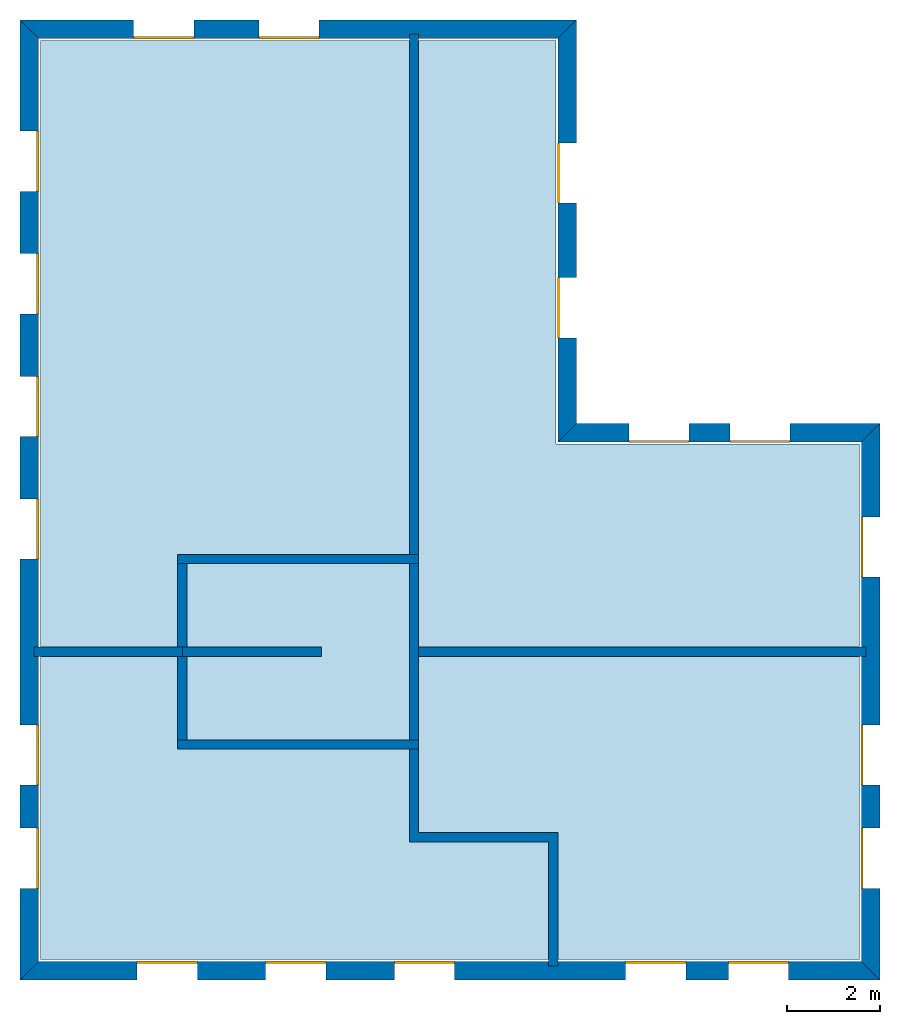
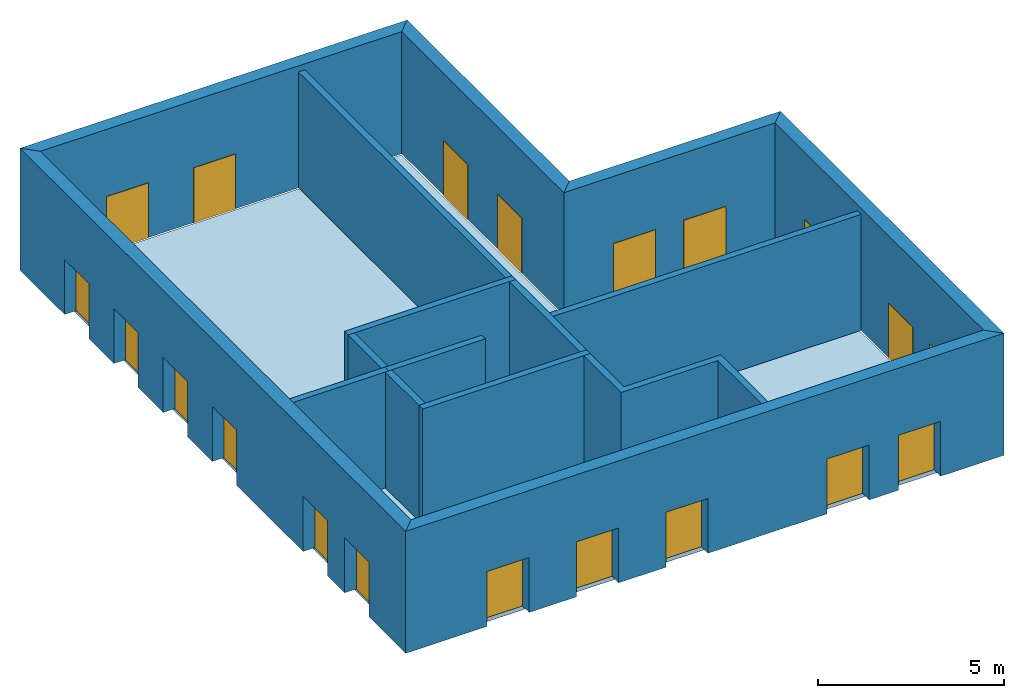
# One storey: 20 windows, 15 walls, 1 slab, 20 openings.
"""IFC4 building model written with IfcOpenShell, lengths in metres."""

from ifc_helpers import new_model, si_unit, origin_with_axes, place, context, subcontext, project, spatial, line, indexed_curve, outline, extrude, element, fill, save


model = new_model("IFC4")

# Units and contexts
model_context = context("Model", 3, precision=1e-05, world=origin_with_axes())
body_context = subcontext(model_context, "Body", "Model", "MODEL_VIEW")
ifc_project = project(units=[si_unit("AREAUNIT", "SQUARE_METRE"), si_unit("VOLUMEUNIT", "CUBIC_METRE"), si_unit("LENGTHUNIT", "METRE")], contexts=[model_context])

# Site, building, storey
site = spatial("IfcSite", under=ifc_project)
building = spatial("IfcBuilding", under=site, Name="Building 2")
storey_placement = place(None, origin_with_axes())
storey = spatial("IfcBuildingStorey", under=building, at=storey_placement, Name="01 Storey")

# Slab
slab_placement = place(storey_placement, origin_with_axes())
element("IfcSlab", 1, at=slab_placement, inside=storey, Name="Slab", context=body_context, shape_type="SweptSolid", body=[
    extrude(outline(indexed_curve([(22.099464, -3.599175), (15.553354, -3.599175), (15.553354, 5.1082), (4.433354, 5.1082), (4.433354, -14.719175), (22.099464, -14.719175)], segments=[line(1, 2), line(2, 3), line(3, 4), line(4, 5), line(5, 6)])), origin_with_axes(), (0.0, 0.0, -1.0), 0.2),
])

# Walls
wall_1_placement = place(storey_placement, origin_with_axes())
element("IfcWall", 2, at=wall_1_placement, inside=storey, Name="Wall", context=body_context, shape_type="SweptSolid", body=[
    extrude(outline(indexed_curve([(7.593354, -7.978543), (4.293354, -7.978543), (4.293354, -8.178543), (7.593354, -8.178543)], segments=[line(1, 2), line(2, 3), line(3, 4)])), origin_with_axes(), (0.0, 0.0, 1.0), 3.8),
])
wall_2_placement = place(storey_placement, origin_with_axes())
element("IfcWall", 3, at=wall_2_placement, inside=storey, Name="Wall", context=body_context, shape_type="SweptSolid", body=[
    extrude(outline(indexed_curve([(12.593354, 5.2482), (12.393354, 5.2482), (12.393354, -6.178543), (12.593354, -6.178543)], segments=[line(1, 2), line(2, 3), line(3, 4)])), origin_with_axes(), (0.0, 0.0, 1.0), 3.8),
])
wall_3_placement = place(storey_placement, origin_with_axes())
element("IfcWall", 4, at=wall_3_placement, inside=storey, Name="Wall", context=body_context, shape_type="SweptSolid", body=[
    extrude(outline(indexed_curve([(22.239464, -7.978543), (12.393354, -7.978543), (12.393354, -8.178543), (22.239464, -8.178543)], segments=[line(1, 2), line(2, 3), line(3, 4)])), origin_with_axes(), (0.0, 0.0, 1.0), 3.8),
])
wall_4_placement = place(storey_placement, origin_with_axes())
element("IfcWall", 5, at=wall_4_placement, inside=storey, Name="Wall", context=body_context, shape_type="SweptSolid", body=[
    extrude(outline(indexed_curve([(15.593354, -11.978543), (12.593354, -11.978543), (12.593354, -9.978543), (12.393354, -9.978543), (12.393354, -12.178543), (15.393354, -12.178543), (15.393354, -14.859175), (15.593354, -14.859175)], segments=[line(1, 2), line(2, 3), line(3, 4), line(4, 5), line(5, 6), line(6, 7), line(7, 8)])), origin_with_axes(), (0.0, 0.0, 1.0), 3.8),
])

# Wall, openings, windows
wall_5_placement = place(storey_placement, origin_with_axes())
wall_5 = element("IfcWall", 6, at=wall_5_placement, inside=storey, Name="Facade", context=body_context, shape_type="SweptSolid", body=[
    extrude(outline(indexed_curve([(22.139464, -3.559175), (15.593354, -3.559175), (15.993354, -3.159175), (22.539464, -3.159175)], segments=[line(1, 2), line(2, 3), line(3, 4)])), origin_with_axes(), (0.0, 0.0, 1.0), 4.0),
])
opening_1_placement = place(wall_5_placement, origin_with_axes())
opening_1 = element("IfcOpeningElement", 7, at=opening_1_placement, cuts=wall_5, Name="Opening", context=body_context, shape_type="SweptSolid", body=[
    extrude(outline(indexed_curve([(20.6074273333333, -3.119175), (20.6074273333333, -3.619175), (19.3074273333333, -3.619175), (19.3074273333333, -3.119175)], segments=[line(1, 2), line(2, 3), line(3, 4)])), origin_with_axes(), (0.0, 0.0, 1.0), 1.8),
])
opening_2_placement = place(wall_5_placement, origin_with_axes())
opening_2 = element("IfcOpeningElement", 8, at=opening_2_placement, cuts=wall_5, Name="Opening", context=body_context, shape_type="SweptSolid", body=[
    extrude(outline(indexed_curve([(18.4253906666667, -3.119175), (18.4253906666667, -3.619175), (17.1253906666667, -3.619175), (17.1253906666667, -3.119175)], segments=[line(1, 2), line(2, 3), line(3, 4)])), origin_with_axes(), (0.0, 0.0, 1.0), 1.8),
])
window_1_placement = place(storey_placement, origin_with_axes())
window_1 = element("IfcWindow", 9, at=window_1_placement, inside=storey, Name="Window", PredefinedType="WINDOW", context=body_context, shape_type="SweptSolid", body=[
    extrude(outline(indexed_curve([(20.6074273333333, -3.519175), (20.6074273333333, -3.569175), (19.3074273333333, -3.569175), (19.3074273333333, -3.519175)], segments=[line(1, 2), line(2, 3), line(3, 4)])), origin_with_axes(), (0.0, 0.0, 1.0), 1.8),
])
fill(opening_1, window_1)
window_2_placement = place(storey_placement, origin_with_axes())
window_2 = element("IfcWindow", 10, at=window_2_placement, inside=storey, Name="Window", PredefinedType="WINDOW", context=body_context, shape_type="SweptSolid", body=[
    extrude(outline(indexed_curve([(18.4253906666667, -3.519175), (18.4253906666667, -3.569175), (17.1253906666667, -3.569175), (17.1253906666667, -3.519175)], segments=[line(1, 2), line(2, 3), line(3, 4)])), origin_with_axes(), (0.0, 0.0, 1.0), 1.8),
])
fill(opening_2, window_2)

wall_6_placement = place(storey_placement, origin_with_axes())
wall_6 = element("IfcWall", 11, at=wall_6_placement, inside=storey, Name="Facade", context=body_context, shape_type="SweptSolid", body=[
    extrude(outline(indexed_curve([(15.593354, -3.559175), (15.593354, 5.1482), (15.993354, 5.5482), (15.993354, -3.159175)], segments=[line(1, 2), line(2, 3), line(3, 4)])), origin_with_axes(), (0.0, 0.0, 1.0), 4.0),
])
opening_3_placement = place(wall_6_placement, origin_with_axes())
opening_3 = element("IfcOpeningElement", 12, at=opening_3_placement, cuts=wall_6, Name="Opening", context=body_context, shape_type="SweptSolid", body=[
    extrude(outline(indexed_curve([(16.033354, -1.30671666666667), (15.533354, -1.30671666666667), (15.533354, -0.00671666666666659), (16.033354, -0.00671666666666659)], segments=[line(1, 2), line(2, 3), line(3, 4)])), origin_with_axes(), (0.0, 0.0, 1.0), 1.8),
])
opening_4_placement = place(wall_6_placement, origin_with_axes())
opening_4 = element("IfcOpeningElement", 13, at=opening_4_placement, cuts=wall_6, Name="Opening", context=body_context, shape_type="SweptSolid", body=[
    extrude(outline(indexed_curve([(16.033354, 1.59574166666667), (15.533354, 1.59574166666667), (15.533354, 2.89574166666667), (16.033354, 2.89574166666667)], segments=[line(1, 2), line(2, 3), line(3, 4)])), origin_with_axes(), (0.0, 0.0, 1.0), 1.8),
])
window_3_placement = place(storey_placement, origin_with_axes())
window_3 = element("IfcWindow", 14, at=window_3_placement, inside=storey, Name="Window", PredefinedType="WINDOW", context=body_context, shape_type="SweptSolid", body=[
    extrude(outline(indexed_curve([(15.633354, -1.30671666666667), (15.583354, -1.30671666666667), (15.583354, -0.00671666666666659), (15.633354, -0.00671666666666659)], segments=[line(1, 2), line(2, 3), line(3, 4)])), origin_with_axes(), (0.0, 0.0, 1.0), 1.8),
])
fill(opening_3, window_3)
window_4_placement = place(storey_placement, origin_with_axes())
window_4 = element("IfcWindow", 15, at=window_4_placement, inside=storey, Name="Window", PredefinedType="WINDOW", context=body_context, shape_type="SweptSolid", body=[
    extrude(outline(indexed_curve([(15.633354, 1.59574166666667), (15.583354, 1.59574166666667), (15.583354, 2.89574166666667), (15.633354, 2.89574166666667)], segments=[line(1, 2), line(2, 3), line(3, 4)])), origin_with_axes(), (0.0, 0.0, 1.0), 1.8),
])
fill(opening_4, window_4)

wall_7_placement = place(storey_placement, origin_with_axes())
wall_7 = element("IfcWall", 16, at=wall_7_placement, inside=storey, Name="Facade", context=body_context, shape_type="SweptSolid", body=[
    extrude(outline(indexed_curve([(15.593354, 5.1482), (4.393354, 5.1482), (3.993354, 5.5482), (15.993354, 5.5482)], segments=[line(1, 2), line(2, 3), line(3, 4)])), origin_with_axes(), (0.0, 0.0, 1.0), 4.0),
])
opening_5_placement = place(wall_7_placement, origin_with_axes())
opening_5 = element("IfcOpeningElement", 17, at=opening_5_placement, cuts=wall_7, Name="Opening", context=body_context, shape_type="SweptSolid", body=[
    extrude(outline(indexed_curve([(10.443354, 5.5882), (10.443354, 5.0882), (9.143354, 5.0882), (9.143354, 5.5882)], segments=[line(1, 2), line(2, 3), line(3, 4)])), origin_with_axes(), (0.0, 0.0, 1.0), 1.8),
])
opening_6_placement = place(wall_7_placement, origin_with_axes())
opening_6 = element("IfcOpeningElement", 18, at=opening_6_placement, cuts=wall_7, Name="Opening", context=body_context, shape_type="SweptSolid", body=[
    extrude(outline(indexed_curve([(7.743354, 5.5882), (7.743354, 5.0882), (6.443354, 5.0882), (6.443354, 5.5882)], segments=[line(1, 2), line(2, 3), line(3, 4)])), origin_with_axes(), (0.0, 0.0, 1.0), 1.8),
])
window_5_placement = place(storey_placement, origin_with_axes())
window_5 = element("IfcWindow", 19, at=window_5_placement, inside=storey, Name="Window", PredefinedType="WINDOW", context=body_context, shape_type="SweptSolid", body=[
    extrude(outline(indexed_curve([(10.443354, 5.1882), (10.443354, 5.1382), (9.143354, 5.1382), (9.143354, 5.1882)], segments=[line(1, 2), line(2, 3), line(3, 4)])), origin_with_axes(), (0.0, 0.0, 1.0), 1.8),
])
fill(opening_5, window_5)
window_6_placement = place(storey_placement, origin_with_axes())
window_6 = element("IfcWindow", 20, at=window_6_placement, inside=storey, Name="Window", PredefinedType="WINDOW", context=body_context, shape_type="SweptSolid", body=[
    extrude(outline(indexed_curve([(7.743354, 5.1882), (7.743354, 5.1382), (6.443354, 5.1382), (6.443354, 5.1882)], segments=[line(1, 2), line(2, 3), line(3, 4)])), origin_with_axes(), (0.0, 0.0, 1.0), 1.8),
])
fill(opening_6, window_6)

wall_8_placement = place(storey_placement, origin_with_axes())
wall_8 = element("IfcWall", 21, at=wall_8_placement, inside=storey, Name="Facade", context=body_context, shape_type="SweptSolid", body=[
    extrude(outline(indexed_curve([(4.393354, 5.1482), (4.393354, -14.759175), (3.993354, -15.159175), (3.993354, 5.5482)], segments=[line(1, 2), line(2, 3), line(3, 4)])), origin_with_axes(), (0.0, 0.0, 1.0), 4.0),
])
opening_7_placement = place(wall_8_placement, origin_with_axes())
opening_7 = element("IfcOpeningElement", 22, at=opening_7_placement, cuts=wall_8, Name="Opening", context=body_context, shape_type="SweptSolid", body=[
    extrude(outline(indexed_curve([(3.953354, 3.1528514), (4.453354, 3.1528514), (4.453354, 1.8528514), (3.953354, 1.8528514)], segments=[line(1, 2), line(2, 3), line(3, 4)])), origin_with_axes(), (0.0, 0.0, 1.0), 1.8),
])
opening_8_placement = place(wall_8_placement, origin_with_axes())
opening_8 = element("IfcOpeningElement", 23, at=opening_8_placement, cuts=wall_8, Name="Opening", context=body_context, shape_type="SweptSolid", body=[
    extrude(outline(indexed_curve([(3.953354, 0.507502800000001), (4.453354, 0.507502800000001), (4.453354, -0.792497199999999), (3.953354, -0.792497199999999)], segments=[line(1, 2), line(2, 3), line(3, 4)])), origin_with_axes(), (0.0, 0.0, 1.0), 1.8),
])
opening_9_placement = place(wall_8_placement, origin_with_axes())
opening_9 = element("IfcOpeningElement", 24, at=opening_9_placement, cuts=wall_8, Name="Opening", context=body_context, shape_type="SweptSolid", body=[
    extrude(outline(indexed_curve([(3.953354, -2.1378458), (4.453354, -2.1378458), (4.453354, -3.4378458), (3.953354, -3.4378458)], segments=[line(1, 2), line(2, 3), line(3, 4)])), origin_with_axes(), (0.0, 0.0, 1.0), 1.8),
])
opening_10_placement = place(wall_8_placement, origin_with_axes())
opening_10 = element("IfcOpeningElement", 25, at=opening_10_placement, cuts=wall_8, Name="Opening", context=body_context, shape_type="SweptSolid", body=[
    extrude(outline(indexed_curve([(3.953354, -4.7831944), (4.453354, -4.7831944), (4.453354, -6.0831944), (3.953354, -6.0831944)], segments=[line(1, 2), line(2, 3), line(3, 4)])), origin_with_axes(), (0.0, 0.0, 1.0), 1.8),
])
opening_11_placement = place(wall_8_placement, origin_with_axes())
opening_11 = element("IfcOpeningElement", 26, at=opening_11_placement, cuts=wall_8, Name="Opening", context=body_context, shape_type="SweptSolid", body=[
    extrude(outline(indexed_curve([(3.953354, -9.65542033333333), (4.453354, -9.65542033333333), (4.453354, -10.9554203333333), (3.953354, -10.9554203333333)], segments=[line(1, 2), line(2, 3), line(3, 4)])), origin_with_axes(), (0.0, 0.0, 1.0), 1.8),
])
opening_12_placement = place(wall_8_placement, origin_with_axes())
opening_12 = element("IfcOpeningElement", 27, at=opening_12_placement, cuts=wall_8, Name="Opening", context=body_context, shape_type="SweptSolid", body=[
    extrude(outline(indexed_curve([(3.953354, -11.8822976666667), (4.453354, -11.8822976666667), (4.453354, -13.1822976666667), (3.953354, -13.1822976666667)], segments=[line(1, 2), line(2, 3), line(3, 4)])), origin_with_axes(), (0.0, 0.0, 1.0), 1.8),
])
window_7_placement = place(storey_placement, origin_with_axes())
window_7 = element("IfcWindow", 28, at=window_7_placement, inside=storey, Name="Window", PredefinedType="WINDOW", context=body_context, shape_type="SweptSolid", body=[
    extrude(outline(indexed_curve([(4.353354, 3.1528514), (4.403354, 3.1528514), (4.403354, 1.8528514), (4.353354, 1.8528514)], segments=[line(1, 2), line(2, 3), line(3, 4)])), origin_with_axes(), (0.0, 0.0, 1.0), 1.8),
])
fill(opening_7, window_7)
window_8_placement = place(storey_placement, origin_with_axes())
window_8 = element("IfcWindow", 29, at=window_8_placement, inside=storey, Name="Window", PredefinedType="WINDOW", context=body_context, shape_type="SweptSolid", body=[
    extrude(outline(indexed_curve([(4.353354, 0.507502800000001), (4.403354, 0.507502800000001), (4.403354, -0.792497199999999), (4.353354, -0.792497199999999)], segments=[line(1, 2), line(2, 3), line(3, 4)])), origin_with_axes(), (0.0, 0.0, 1.0), 1.8),
])
fill(opening_8, window_8)
window_9_placement = place(storey_placement, origin_with_axes())
window_9 = element("IfcWindow", 30, at=window_9_placement, inside=storey, Name="Window", PredefinedType="WINDOW", context=body_context, shape_type="SweptSolid", body=[
    extrude(outline(indexed_curve([(4.353354, -2.1378458), (4.403354, -2.1378458), (4.403354, -3.4378458), (4.353354, -3.4378458)], segments=[line(1, 2), line(2, 3), line(3, 4)])), origin_with_axes(), (0.0, 0.0, 1.0), 1.8),
])
fill(opening_9, window_9)
window_10_placement = place(storey_placement, origin_with_axes())
window_10 = element("IfcWindow", 31, at=window_10_placement, inside=storey, Name="Window", PredefinedType="WINDOW", context=body_context, shape_type="SweptSolid", body=[
    extrude(outline(indexed_curve([(4.353354, -4.7831944), (4.403354, -4.7831944), (4.403354, -6.0831944), (4.353354, -6.0831944)], segments=[line(1, 2), line(2, 3), line(3, 4)])), origin_with_axes(), (0.0, 0.0, 1.0), 1.8),
])
fill(opening_10, window_10)
window_11_placement = place(storey_placement, origin_with_axes())
window_11 = element("IfcWindow", 32, at=window_11_placement, inside=storey, Name="Window", PredefinedType="WINDOW", context=body_context, shape_type="SweptSolid", body=[
    extrude(outline(indexed_curve([(4.353354, -9.65542033333333), (4.403354, -9.65542033333333), (4.403354, -10.9554203333333), (4.353354, -10.9554203333333)], segments=[line(1, 2), line(2, 3), line(3, 4)])), origin_with_axes(), (0.0, 0.0, 1.0), 1.8),
])
fill(opening_11, window_11)
window_12_placement = place(storey_placement, origin_with_axes())
window_12 = element("IfcWindow", 33, at=window_12_placement, inside=storey, Name="Window", PredefinedType="WINDOW", context=body_context, shape_type="SweptSolid", body=[
    extrude(outline(indexed_curve([(4.353354, -11.8822976666667), (4.403354, -11.8822976666667), (4.403354, -13.1822976666667), (4.353354, -13.1822976666667)], segments=[line(1, 2), line(2, 3), line(3, 4)])), origin_with_axes(), (0.0, 0.0, 1.0), 1.8),
])
fill(opening_12, window_12)

wall_9_placement = place(storey_placement, origin_with_axes())
wall_9 = element("IfcWall", 34, at=wall_9_placement, inside=storey, Name="Facade", context=body_context, shape_type="SweptSolid", body=[
    extrude(outline(indexed_curve([(4.393354, -14.759175), (22.139464, -14.759175), (22.539464, -15.159175), (3.993354, -15.159175)], segments=[line(1, 2), line(2, 3), line(3, 4)])), origin_with_axes(), (0.0, 0.0, 1.0), 4.0),
])
opening_13_placement = place(wall_9_placement, origin_with_axes())
opening_13 = element("IfcOpeningElement", 35, at=opening_13_placement, cuts=wall_9, Name="Opening", context=body_context, shape_type="SweptSolid", body=[
    extrude(outline(indexed_curve([(17.058724, -15.199175), (17.058724, -14.699175), (18.358724, -14.699175), (18.358724, -15.199175)], segments=[line(1, 2), line(2, 3), line(3, 4)])), origin_with_axes(), (0.0, 0.0, 1.0), 1.8),
])
opening_14_placement = place(wall_9_placement, origin_with_axes())
opening_14 = element("IfcOpeningElement", 36, at=opening_14_placement, cuts=wall_9, Name="Opening", context=body_context, shape_type="SweptSolid", body=[
    extrude(outline(indexed_curve([(19.274094, -15.199175), (19.274094, -14.699175), (20.574094, -14.699175), (20.574094, -15.199175)], segments=[line(1, 2), line(2, 3), line(3, 4)])), origin_with_axes(), (0.0, 0.0, 1.0), 1.8),
])
opening_15_placement = place(wall_9_placement, origin_with_axes())
opening_15 = element("IfcOpeningElement", 37, at=opening_15_placement, cuts=wall_9, Name="Opening", context=body_context, shape_type="SweptSolid", body=[
    extrude(outline(indexed_curve([(6.518354, -15.199175), (6.518354, -14.699175), (7.818354, -14.699175), (7.818354, -15.199175)], segments=[line(1, 2), line(2, 3), line(3, 4)])), origin_with_axes(), (0.0, 0.0, 1.0), 1.8),
])
opening_16_placement = place(wall_9_placement, origin_with_axes())
opening_16 = element("IfcOpeningElement", 38, at=opening_16_placement, cuts=wall_9, Name="Opening", context=body_context, shape_type="SweptSolid", body=[
    extrude(outline(indexed_curve([(9.293354, -15.199175), (9.293354, -14.699175), (10.593354, -14.699175), (10.593354, -15.199175)], segments=[line(1, 2), line(2, 3), line(3, 4)])), origin_with_axes(), (0.0, 0.0, 1.0), 1.8),
])
opening_17_placement = place(wall_9_placement, origin_with_axes())
opening_17 = element("IfcOpeningElement", 39, at=opening_17_placement, cuts=wall_9, Name="Opening", context=body_context, shape_type="SweptSolid", body=[
    extrude(outline(indexed_curve([(12.068354, -15.199175), (12.068354, -14.699175), (13.368354, -14.699175), (13.368354, -15.199175)], segments=[line(1, 2), line(2, 3), line(3, 4)])), origin_with_axes(), (0.0, 0.0, 1.0), 1.8),
])
window_13_placement = place(storey_placement, origin_with_axes())
window_13 = element("IfcWindow", 40, at=window_13_placement, inside=storey, Name="Window", PredefinedType="WINDOW", context=body_context, shape_type="SweptSolid", body=[
    extrude(outline(indexed_curve([(17.058724, -14.799175), (17.058724, -14.749175), (18.358724, -14.749175), (18.358724, -14.799175)], segments=[line(1, 2), line(2, 3), line(3, 4)])), origin_with_axes(), (0.0, 0.0, 1.0), 1.8),
])
fill(opening_13, window_13)
window_14_placement = place(storey_placement, origin_with_axes())
window_14 = element("IfcWindow", 41, at=window_14_placement, inside=storey, Name="Window", PredefinedType="WINDOW", context=body_context, shape_type="SweptSolid", body=[
    extrude(outline(indexed_curve([(19.274094, -14.799175), (19.274094, -14.749175), (20.574094, -14.749175), (20.574094, -14.799175)], segments=[line(1, 2), line(2, 3), line(3, 4)])), origin_with_axes(), (0.0, 0.0, 1.0), 1.8),
])
fill(opening_14, window_14)
window_15_placement = place(storey_placement, origin_with_axes())
window_15 = element("IfcWindow", 42, at=window_15_placement, inside=storey, Name="Window", PredefinedType="WINDOW", context=body_context, shape_type="SweptSolid", body=[
    extrude(outline(indexed_curve([(6.518354, -14.799175), (6.518354, -14.749175), (7.818354, -14.749175), (7.818354, -14.799175)], segments=[line(1, 2), line(2, 3), line(3, 4)])), origin_with_axes(), (0.0, 0.0, 1.0), 1.8),
])
fill(opening_15, window_15)
window_16_placement = place(storey_placement, origin_with_axes())
window_16 = element("IfcWindow", 43, at=window_16_placement, inside=storey, Name="Window", PredefinedType="WINDOW", context=body_context, shape_type="SweptSolid", body=[
    extrude(outline(indexed_curve([(9.293354, -14.799175), (9.293354, -14.749175), (10.593354, -14.749175), (10.593354, -14.799175)], segments=[line(1, 2), line(2, 3), line(3, 4)])), origin_with_axes(), (0.0, 0.0, 1.0), 1.8),
])
fill(opening_16, window_16)
window_17_placement = place(storey_placement, origin_with_axes())
window_17 = element("IfcWindow", 44, at=window_17_placement, inside=storey, Name="Window", PredefinedType="WINDOW", context=body_context, shape_type="SweptSolid", body=[
    extrude(outline(indexed_curve([(12.068354, -14.799175), (12.068354, -14.749175), (13.368354, -14.749175), (13.368354, -14.799175)], segments=[line(1, 2), line(2, 3), line(3, 4)])), origin_with_axes(), (0.0, 0.0, 1.0), 1.8),
])
fill(opening_17, window_17)

wall_10_placement = place(storey_placement, origin_with_axes())
wall_10 = element("IfcWall", 45, at=wall_10_placement, inside=storey, Name="Facade", context=body_context, shape_type="SweptSolid", body=[
    extrude(outline(indexed_curve([(22.139464, -14.759175), (22.139464, -3.559175), (22.539464, -3.159175), (22.539464, -15.159175)], segments=[line(1, 2), line(2, 3), line(3, 4)])), origin_with_axes(), (0.0, 0.0, 1.0), 4.0),
])
opening_18_placement = place(wall_10_placement, origin_with_axes())
opening_18 = element("IfcOpeningElement", 46, at=opening_18_placement, cuts=wall_10, Name="Opening", context=body_context, shape_type="SweptSolid", body=[
    extrude(outline(indexed_curve([(22.579464, -6.468859), (22.079464, -6.468859), (22.079464, -5.168859), (22.579464, -5.168859)], segments=[line(1, 2), line(2, 3), line(3, 4)])), origin_with_axes(), (0.0, 0.0, 1.0), 1.8),
])
opening_19_placement = place(wall_10_placement, origin_with_axes())
opening_19 = element("IfcOpeningElement", 47, at=opening_19_placement, cuts=wall_10, Name="Opening", context=body_context, shape_type="SweptSolid", body=[
    extrude(outline(indexed_curve([(22.579464, -13.1822976666667), (22.079464, -13.1822976666667), (22.079464, -11.8822976666667), (22.579464, -11.8822976666667)], segments=[line(1, 2), line(2, 3), line(3, 4)])), origin_with_axes(), (0.0, 0.0, 1.0), 1.8),
])
opening_20_placement = place(wall_10_placement, origin_with_axes())
opening_20 = element("IfcOpeningElement", 48, at=opening_20_placement, cuts=wall_10, Name="Opening", context=body_context, shape_type="SweptSolid", body=[
    extrude(outline(indexed_curve([(22.579464, -10.9554203333333), (22.079464, -10.9554203333333), (22.079464, -9.65542033333333), (22.579464, -9.65542033333333)], segments=[line(1, 2), line(2, 3), line(3, 4)])), origin_with_axes(), (0.0, 0.0, 1.0), 1.8),
])
window_18_placement = place(storey_placement, origin_with_axes())
window_18 = element("IfcWindow", 49, at=window_18_placement, inside=storey, Name="Window", PredefinedType="WINDOW", context=body_context, shape_type="SweptSolid", body=[
    extrude(outline(indexed_curve([(22.179464, -6.468859), (22.129464, -6.468859), (22.129464, -5.168859), (22.179464, -5.168859)], segments=[line(1, 2), line(2, 3), line(3, 4)])), origin_with_axes(), (0.0, 0.0, 1.0), 1.8),
])
fill(opening_18, window_18)
window_19_placement = place(storey_placement, origin_with_axes())
window_19 = element("IfcWindow", 50, at=window_19_placement, inside=storey, Name="Window", PredefinedType="WINDOW", context=body_context, shape_type="SweptSolid", body=[
    extrude(outline(indexed_curve([(22.179464, -13.1822976666667), (22.129464, -13.1822976666667), (22.129464, -11.8822976666667), (22.179464, -11.8822976666667)], segments=[line(1, 2), line(2, 3), line(3, 4)])), origin_with_axes(), (0.0, 0.0, 1.0), 1.8),
])
fill(opening_19, window_19)
window_20_placement = place(storey_placement, origin_with_axes())
window_20 = element("IfcWindow", 51, at=window_20_placement, inside=storey, Name="Window", PredefinedType="WINDOW", context=body_context, shape_type="SweptSolid", body=[
    extrude(outline(indexed_curve([(22.179464, -10.9554203333333), (22.129464, -10.9554203333333), (22.129464, -9.65542033333333), (22.179464, -9.65542033333333)], segments=[line(1, 2), line(2, 3), line(3, 4)])), origin_with_axes(), (0.0, 0.0, 1.0), 1.8),
])
fill(opening_20, window_20)

# Walls
wall_11_placement = place(storey_placement, origin_with_axes())
element("IfcWall", 52, at=wall_11_placement, inside=storey, Name="CoreWall", context=body_context, shape_type="SweptSolid", body=[
    extrude(outline(indexed_curve([(12.593354, -5.978543), (7.393354, -5.978543), (7.393354, -6.178543), (12.593354, -6.178543)], segments=[line(1, 2), line(2, 3), line(3, 4)])), origin_with_axes(), (0.0, 0.0, 1.0), 3.8),
])
wall_12_placement = place(storey_placement, origin_with_axes())
element("IfcWall", 53, at=wall_12_placement, inside=storey, Name="CoreWall", context=body_context, shape_type="SweptSolid", body=[
    extrude(outline(indexed_curve([(7.393354, -10.178543), (12.593354, -10.178543), (12.593354, -9.978543), (7.393354, -9.978543)], segments=[line(1, 2), line(2, 3), line(3, 4)])), origin_with_axes(), (0.0, 0.0, 1.0), 3.8),
])
wall_13_placement = place(storey_placement, origin_with_axes())
element("IfcWall", 54, at=wall_13_placement, inside=storey, Name="CoreWall", context=body_context, shape_type="SweptSolid", body=[
    extrude(outline(indexed_curve([(7.593354, -9.978543), (7.593354, -6.178543), (7.393354, -6.178543), (7.393354, -9.978543)], segments=[line(1, 2), line(2, 3), line(3, 4)])), origin_with_axes(), (0.0, 0.0, 1.0), 3.8),
])
wall_14_placement = place(storey_placement, origin_with_axes())
element("IfcWall", 55, at=wall_14_placement, inside=storey, Name="CoreWall", context=body_context, shape_type="SweptSolid", body=[
    extrude(outline(indexed_curve([(12.393354, -6.178543), (12.393354, -9.978543), (12.593354, -9.978543), (12.593354, -6.178543)], segments=[line(1, 2), line(2, 3), line(3, 4)])), origin_with_axes(), (0.0, 0.0, 1.0), 3.8),
])
wall_15_placement = place(storey_placement, origin_with_axes())
element("IfcWall", 56, at=wall_15_placement, inside=storey, Name="CoreWall", context=body_context, shape_type="SweptSolid", body=[
    extrude(outline(indexed_curve([(10.493354, -7.978543), (7.493354, -7.978543), (7.493354, -8.178543), (10.493354, -8.178543)], segments=[line(1, 2), line(2, 3), line(3, 4)])), origin_with_axes(), (0.0, 0.0, 1.0), 3.8),
])

save(model, "model.ifc")
